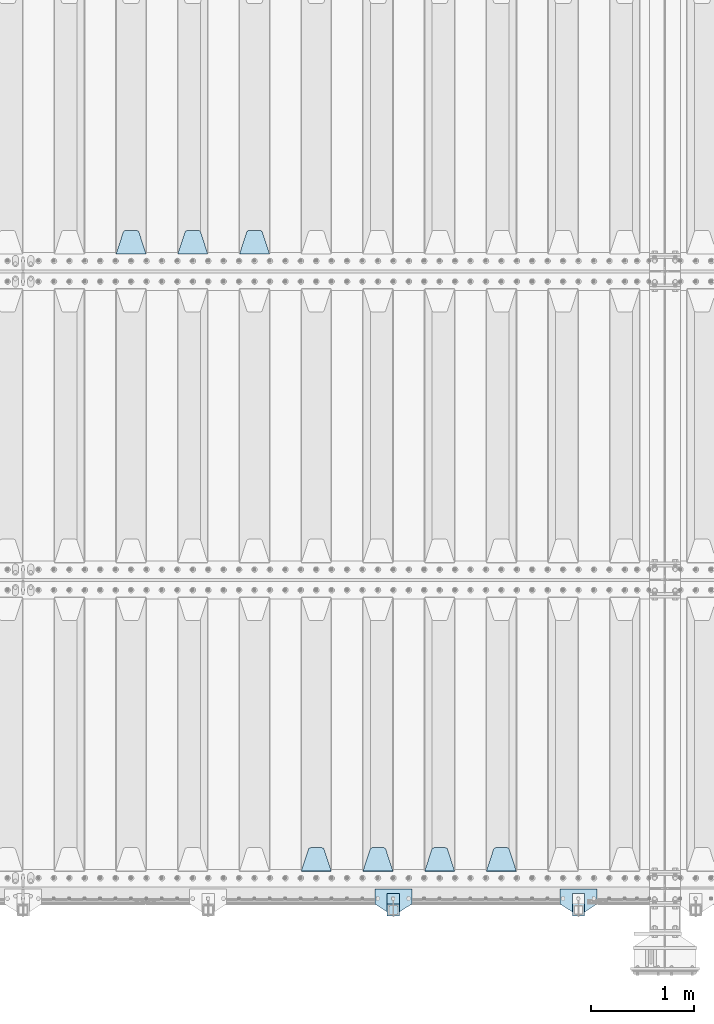
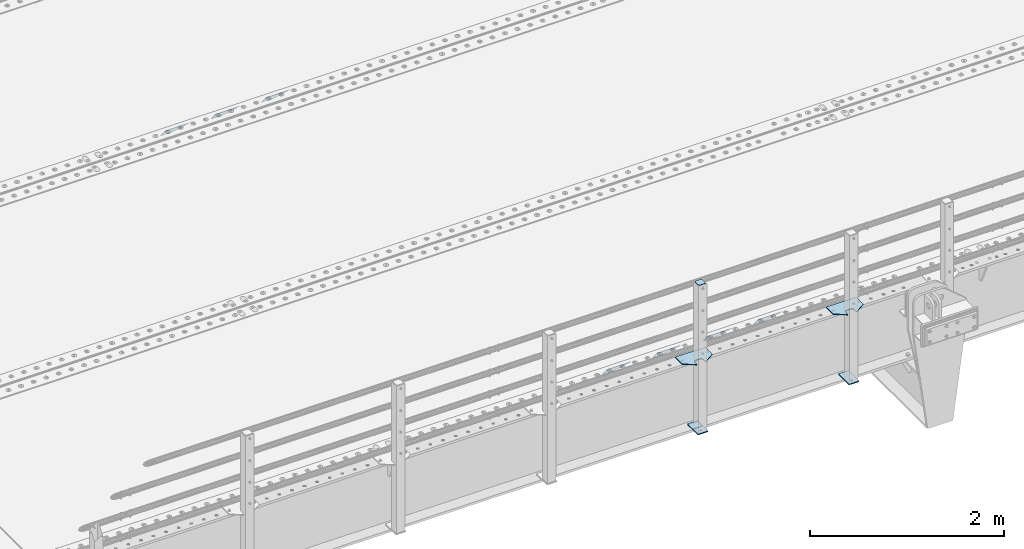
# One storey, part 197 of 240: 13 plates.
"""IFC2X3 building model written with IfcOpenShell, lengths in millimetres."""

from ifc_helpers import new_model, si_unit, frame, origin_with_axes, place, context, subcontext, project, spatial, faceted_brep, material, type_object, element, save


model = new_model("IFC2X3")

# Units and contexts
model_context = context("Model", 3, precision=1e-05, world=origin_with_axes())
body_context = subcontext(model_context, "Body", "Model", "MODEL_VIEW")
ifc_project = project(units=[si_unit("LENGTHUNIT", "METRE", prefix="MILLI"), si_unit("AREAUNIT", "SQUARE_METRE"), si_unit("VOLUMEUNIT", "CUBIC_METRE"), si_unit("MASSUNIT", "GRAM", prefix="KILO"), si_unit("TIMEUNIT", "SECOND"), si_unit("PLANEANGLEUNIT", "RADIAN"), si_unit("SOLIDANGLEUNIT", "STERADIAN"), si_unit("THERMODYNAMICTEMPERATUREUNIT", "DEGREE_CELSIUS"), si_unit("LUMINOUSINTENSITYUNIT", "LUMEN")], contexts=[model_context])

# Site, building, storey
site_placement = place(None, origin_with_axes())
site = spatial("IfcSite", under=ifc_project, at=site_placement, CompositionType="ELEMENT")
building_placement = place(site_placement, origin_with_axes())
building = spatial("IfcBuilding", under=site, at=building_placement, Name="Standard", CompositionType="ELEMENT")
storey_placement = place(building_placement, origin_with_axes())
storey = spatial("IfcBuildingStorey", under=building, at=storey_placement, Name="Undefined", CompositionType="ELEMENT", Elevation=0.0)

# Plates
ifc_material_1 = material(Name="STEEL/S355N")
plate_type_1 = type_object("IfcPlateType", PredefinedType="NOTDEFINED")
plate_1_placement = place(storey_placement, frame((48995.0, 30168.232233047, -1.76776695296758), z_axis=(0.0, 0.707106781186547, -0.707106781186548), x_axis=(-1.0, 0.0, 0.0)))
element("IfcPlate", 1, at=plate_1_placement, inside=storey, type_object=plate_type_1, material=ifc_material_1, context=body_context, shape_type="Brep", body=[
    faceted_brep([(0.0, -2.5, 0.0), (69.345504679477, -2.50000000000364, 300.171731424827), (69.345504679477, 2.49999999999636, 300.171731424827), (0.0, 2.5, 0.0), (70.927406119954, -2.50000000000364, 304.897442415397), (70.927406119954, 2.49999999999636, 304.897442415397), (73.3818627772271, -2.50000000000728, 309.234538108525), (73.3818627772271, 2.49999999999636, 309.234538108529), (76.6187032999587, -2.50000000000728, 313.023683126099), (76.6187032999587, 2.49999999999636, 313.023683126103), (80.5190132705029, -2.50000000000364, 316.125672595368), (80.5190132705029, 2.49999999999636, 316.125672595368), (84.9395038596849, -2.50000000000364, 318.426546230472), (84.9395038596849, 2.49999999999636, 318.426546230472), (89.7177759439219, -2.5, 319.841774983277), (89.7177759439219, 2.49999999999636, 319.841774983273), (94.6782862926484, -2.50000000000364, 320.319366455074), (94.6782862926484, 2.49999999999636, 320.319366455074), (195.321713707352, -2.50000000000364, 320.319366455074), (195.321713707352, 2.49999999999636, 320.319366455074), (200.282224056078, -2.50000000000364, 319.841774983273), (200.282224056078, 2.49999999999636, 319.841774983273), (205.060496140315, -2.50000000000364, 318.426546230472), (205.060496140315, 2.49999999999636, 318.426546230472), (209.480986729497, -2.50000000000364, 316.125672595368), (209.480986729497, 2.49999999999636, 316.125672595368), (213.381296700041, -2.50000000000728, 313.023683126099), (213.381296700041, 2.49999999999272, 313.023683126099), (216.618137222766, -2.50000000000364, 309.234538108522), (216.618137222766, 2.49999999999636, 309.234538108522), (219.072593880039, -2.50000000000364, 304.897442415397), (219.072593880039, 2.49999999999636, 304.897442415397), (220.654495320523, -2.50000000000364, 300.171731424827), (220.654495320523, 2.49999999999636, 300.171731424827), (290.0, -2.50000000000364, -3.63797880709171e-12), (290.0, 2.49999999999636, -3.63797880709171e-12)], [[[0, 1, 2, 3]], [[1, 4, 5, 2]], [[4, 6, 7, 5]], [[6, 8, 9, 7]], [[8, 10, 11, 9]], [[10, 12, 13, 11]], [[12, 14, 15, 13]], [[14, 16, 17, 15]], [[16, 18, 19, 17]], [[18, 20, 21, 19]], [[20, 22, 23, 21]], [[22, 24, 25, 23]], [[24, 26, 27, 25]], [[26, 28, 29, 27]], [[28, 30, 31, 29]], [[30, 32, 33, 31]], [[32, 34, 35, 33]], [[34, 0, 3, 35]], [[5, 7, 9, 11, 13, 15, 17, 19, 21, 23, 25, 27, 29, 31, 33, 35, 3, 2]], [[34, 32, 30, 28, 26, 24, 22, 20, 18, 16, 14, 12, 10, 8, 6, 4, 1, 0]]]),
])
plate_2_placement = place(storey_placement, frame((48395.0, 30168.232233047, -1.76776695296758), z_axis=(0.0, 0.707106781186547, -0.707106781186548), x_axis=(-1.0, 0.0, 0.0)))
element("IfcPlate", 2, at=plate_2_placement, inside=storey, type_object=plate_type_1, material=ifc_material_1, context=body_context, shape_type="Brep", body=[
    faceted_brep([(0.0, -2.5, 0.0), (69.345504679477, -2.50000000000364, 300.171731424827), (69.345504679477, 2.49999999999636, 300.171731424827), (0.0, 2.5, 0.0), (70.927406119954, -2.50000000000364, 304.897442415397), (70.927406119954, 2.49999999999636, 304.897442415397), (73.3818627772271, -2.50000000000728, 309.234538108525), (73.3818627772271, 2.49999999999636, 309.234538108529), (76.6187032999587, -2.50000000000728, 313.023683126099), (76.6187032999587, 2.49999999999636, 313.023683126103), (80.5190132705029, -2.50000000000364, 316.125672595368), (80.5190132705029, 2.49999999999636, 316.125672595368), (84.9395038596849, -2.50000000000364, 318.426546230472), (84.9395038596849, 2.49999999999636, 318.426546230472), (89.7177759439219, -2.5, 319.841774983277), (89.7177759439219, 2.49999999999636, 319.841774983273), (94.6782862926484, -2.50000000000364, 320.319366455074), (94.6782862926484, 2.49999999999636, 320.319366455074), (195.321713707352, -2.50000000000364, 320.319366455074), (195.321713707352, 2.49999999999636, 320.319366455074), (200.282224056078, -2.50000000000364, 319.841774983273), (200.282224056078, 2.49999999999636, 319.841774983273), (205.060496140315, -2.50000000000364, 318.426546230472), (205.060496140315, 2.49999999999636, 318.426546230472), (209.480986729497, -2.50000000000364, 316.125672595368), (209.480986729497, 2.49999999999636, 316.125672595368), (213.381296700041, -2.50000000000728, 313.023683126099), (213.381296700041, 2.49999999999272, 313.023683126099), (216.618137222766, -2.50000000000364, 309.234538108522), (216.618137222766, 2.49999999999636, 309.234538108522), (219.072593880039, -2.50000000000364, 304.897442415397), (219.072593880039, 2.49999999999636, 304.897442415397), (220.654495320523, -2.50000000000364, 300.171731424827), (220.654495320523, 2.49999999999636, 300.171731424827), (290.0, -2.50000000000364, -3.63797880709171e-12), (290.0, 2.49999999999636, -3.63797880709171e-12)], [[[0, 1, 2, 3]], [[1, 4, 5, 2]], [[4, 6, 7, 5]], [[6, 8, 9, 7]], [[8, 10, 11, 9]], [[10, 12, 13, 11]], [[12, 14, 15, 13]], [[14, 16, 17, 15]], [[16, 18, 19, 17]], [[18, 20, 21, 19]], [[20, 22, 23, 21]], [[22, 24, 25, 23]], [[24, 26, 27, 25]], [[26, 28, 29, 27]], [[28, 30, 31, 29]], [[30, 32, 33, 31]], [[32, 34, 35, 33]], [[34, 0, 3, 35]], [[5, 7, 9, 11, 13, 15, 17, 19, 21, 23, 25, 27, 29, 31, 33, 35, 3, 2]], [[34, 32, 30, 28, 26, 24, 22, 20, 18, 16, 14, 12, 10, 8, 6, 4, 1, 0]]]),
])
plate_3_placement = place(storey_placement, frame((47795.0, 30168.232233047, -1.76776695296758), z_axis=(0.0, 0.707106781186547, -0.707106781186548), x_axis=(-1.0, 0.0, 0.0)))
element("IfcPlate", 3, at=plate_3_placement, inside=storey, type_object=plate_type_1, material=ifc_material_1, context=body_context, shape_type="Brep", body=[
    faceted_brep([(0.0, -2.5, 0.0), (69.345504679477, -2.50000000000364, 300.171731424827), (69.345504679477, 2.49999999999636, 300.171731424827), (0.0, 2.5, 0.0), (70.927406119954, -2.50000000000364, 304.897442415397), (70.927406119954, 2.49999999999636, 304.897442415397), (73.3818627772271, -2.50000000000728, 309.234538108525), (73.3818627772271, 2.49999999999636, 309.234538108529), (76.6187032999587, -2.50000000000728, 313.023683126099), (76.6187032999587, 2.49999999999636, 313.023683126103), (80.5190132705029, -2.50000000000364, 316.125672595368), (80.5190132705029, 2.49999999999636, 316.125672595368), (84.9395038596849, -2.50000000000364, 318.426546230472), (84.9395038596849, 2.49999999999636, 318.426546230472), (89.7177759439219, -2.5, 319.841774983277), (89.7177759439219, 2.49999999999636, 319.841774983273), (94.6782862926484, -2.50000000000364, 320.319366455074), (94.6782862926484, 2.49999999999636, 320.319366455074), (195.321713707352, -2.50000000000364, 320.319366455074), (195.321713707352, 2.49999999999636, 320.319366455074), (200.282224056078, -2.50000000000364, 319.841774983273), (200.282224056078, 2.49999999999636, 319.841774983273), (205.060496140315, -2.50000000000364, 318.426546230472), (205.060496140315, 2.49999999999636, 318.426546230472), (209.480986729497, -2.50000000000364, 316.125672595368), (209.480986729497, 2.49999999999636, 316.125672595368), (213.381296700041, -2.50000000000728, 313.023683126099), (213.381296700041, 2.49999999999272, 313.023683126099), (216.618137222766, -2.50000000000364, 309.234538108522), (216.618137222766, 2.49999999999636, 309.234538108522), (219.072593880039, -2.50000000000364, 304.897442415397), (219.072593880039, 2.49999999999636, 304.897442415397), (220.654495320523, -2.50000000000364, 300.171731424827), (220.654495320523, 2.49999999999636, 300.171731424827), (290.0, -2.50000000000364, -3.63797880709171e-12), (290.0, 2.49999999999636, -3.63797880709171e-12)], [[[0, 1, 2, 3]], [[1, 4, 5, 2]], [[4, 6, 7, 5]], [[6, 8, 9, 7]], [[8, 10, 11, 9]], [[10, 12, 13, 11]], [[12, 14, 15, 13]], [[14, 16, 17, 15]], [[16, 18, 19, 17]], [[18, 20, 21, 19]], [[20, 22, 23, 21]], [[22, 24, 25, 23]], [[24, 26, 27, 25]], [[26, 28, 29, 27]], [[28, 30, 31, 29]], [[30, 32, 33, 31]], [[32, 34, 35, 33]], [[34, 0, 3, 35]], [[5, 7, 9, 11, 13, 15, 17, 19, 21, 23, 25, 27, 29, 31, 33, 35, 3, 2]], [[34, 32, 30, 28, 26, 24, 22, 20, 18, 16, 14, 12, 10, 8, 6, 4, 1, 0]]]),
])
plate_4_placement = place(storey_placement, frame((51395.0, 24168.232233047, -1.76776695296758), z_axis=(0.0, 0.707106781186547, -0.707106781186548), x_axis=(-1.0, 0.0, 0.0)))
element("IfcPlate", 4, at=plate_4_placement, inside=storey, type_object=plate_type_1, material=ifc_material_1, context=body_context, shape_type="Brep", body=[
    faceted_brep([(0.0, -2.5, 0.0), (69.345504679477, -2.50000000000364, 300.171731424827), (69.345504679477, 2.49999999999636, 300.171731424827), (0.0, 2.5, 0.0), (70.927406119954, -2.50000000000364, 304.897442415397), (70.927406119954, 2.49999999999636, 304.897442415397), (73.3818627772271, -2.50000000000728, 309.234538108525), (73.3818627772271, 2.49999999999636, 309.234538108529), (76.6187032999587, -2.50000000000728, 313.023683126099), (76.6187032999587, 2.49999999999636, 313.023683126103), (80.5190132705029, -2.50000000000364, 316.125672595368), (80.5190132705029, 2.49999999999636, 316.125672595368), (84.9395038596849, -2.50000000000364, 318.426546230472), (84.9395038596849, 2.49999999999636, 318.426546230472), (89.7177759439219, -2.5, 319.841774983277), (89.7177759439219, 2.49999999999636, 319.841774983273), (94.6782862926484, -2.50000000000364, 320.319366455074), (94.6782862926484, 2.49999999999636, 320.319366455074), (195.321713707352, -2.50000000000364, 320.319366455074), (195.321713707352, 2.49999999999636, 320.319366455074), (200.282224056078, -2.50000000000364, 319.841774983273), (200.282224056078, 2.49999999999636, 319.841774983273), (205.060496140315, -2.50000000000364, 318.426546230472), (205.060496140315, 2.49999999999636, 318.426546230472), (209.480986729497, -2.50000000000364, 316.125672595368), (209.480986729497, 2.49999999999636, 316.125672595368), (213.381296700041, -2.50000000000728, 313.023683126099), (213.381296700041, 2.49999999999272, 313.023683126099), (216.618137222766, -2.50000000000364, 309.234538108522), (216.618137222766, 2.49999999999636, 309.234538108522), (219.072593880039, -2.50000000000364, 304.897442415397), (219.072593880039, 2.49999999999636, 304.897442415397), (220.654495320523, -2.50000000000364, 300.171731424827), (220.654495320523, 2.49999999999636, 300.171731424827), (290.0, -2.50000000000364, -3.63797880709171e-12), (290.0, 2.49999999999636, -3.63797880709171e-12)], [[[0, 1, 2, 3]], [[1, 4, 5, 2]], [[4, 6, 7, 5]], [[6, 8, 9, 7]], [[8, 10, 11, 9]], [[10, 12, 13, 11]], [[12, 14, 15, 13]], [[14, 16, 17, 15]], [[16, 18, 19, 17]], [[18, 20, 21, 19]], [[20, 22, 23, 21]], [[22, 24, 25, 23]], [[24, 26, 27, 25]], [[26, 28, 29, 27]], [[28, 30, 31, 29]], [[30, 32, 33, 31]], [[32, 34, 35, 33]], [[34, 0, 3, 35]], [[5, 7, 9, 11, 13, 15, 17, 19, 21, 23, 25, 27, 29, 31, 33, 35, 3, 2]], [[34, 32, 30, 28, 26, 24, 22, 20, 18, 16, 14, 12, 10, 8, 6, 4, 1, 0]]]),
])
plate_5_placement = place(storey_placement, frame((50795.0, 24168.232233047, -1.76776695296758), z_axis=(0.0, 0.707106781186547, -0.707106781186548), x_axis=(-1.0, 0.0, 0.0)))
element("IfcPlate", 5, at=plate_5_placement, inside=storey, type_object=plate_type_1, material=ifc_material_1, context=body_context, shape_type="Brep", body=[
    faceted_brep([(0.0, -2.5, 0.0), (69.345504679477, -2.50000000000364, 300.171731424827), (69.345504679477, 2.49999999999636, 300.171731424827), (0.0, 2.5, 0.0), (70.927406119954, -2.50000000000364, 304.897442415397), (70.927406119954, 2.49999999999636, 304.897442415397), (73.3818627772271, -2.50000000000728, 309.234538108525), (73.3818627772271, 2.49999999999636, 309.234538108529), (76.6187032999587, -2.50000000000728, 313.023683126099), (76.6187032999587, 2.49999999999636, 313.023683126103), (80.5190132705029, -2.50000000000364, 316.125672595368), (80.5190132705029, 2.49999999999636, 316.125672595368), (84.9395038596849, -2.50000000000364, 318.426546230472), (84.9395038596849, 2.49999999999636, 318.426546230472), (89.7177759439219, -2.5, 319.841774983277), (89.7177759439219, 2.49999999999636, 319.841774983273), (94.6782862926484, -2.50000000000364, 320.319366455074), (94.6782862926484, 2.49999999999636, 320.319366455074), (195.321713707352, -2.50000000000364, 320.319366455074), (195.321713707352, 2.49999999999636, 320.319366455074), (200.282224056078, -2.50000000000364, 319.841774983273), (200.282224056078, 2.49999999999636, 319.841774983273), (205.060496140315, -2.50000000000364, 318.426546230472), (205.060496140315, 2.49999999999636, 318.426546230472), (209.480986729497, -2.50000000000364, 316.125672595368), (209.480986729497, 2.49999999999636, 316.125672595368), (213.381296700041, -2.50000000000728, 313.023683126099), (213.381296700041, 2.49999999999272, 313.023683126099), (216.618137222766, -2.50000000000364, 309.234538108522), (216.618137222766, 2.49999999999636, 309.234538108522), (219.072593880039, -2.50000000000364, 304.897442415397), (219.072593880039, 2.49999999999636, 304.897442415397), (220.654495320523, -2.50000000000364, 300.171731424827), (220.654495320523, 2.49999999999636, 300.171731424827), (290.0, -2.50000000000364, -3.63797880709171e-12), (290.0, 2.49999999999636, -3.63797880709171e-12)], [[[0, 1, 2, 3]], [[1, 4, 5, 2]], [[4, 6, 7, 5]], [[6, 8, 9, 7]], [[8, 10, 11, 9]], [[10, 12, 13, 11]], [[12, 14, 15, 13]], [[14, 16, 17, 15]], [[16, 18, 19, 17]], [[18, 20, 21, 19]], [[20, 22, 23, 21]], [[22, 24, 25, 23]], [[24, 26, 27, 25]], [[26, 28, 29, 27]], [[28, 30, 31, 29]], [[30, 32, 33, 31]], [[32, 34, 35, 33]], [[34, 0, 3, 35]], [[5, 7, 9, 11, 13, 15, 17, 19, 21, 23, 25, 27, 29, 31, 33, 35, 3, 2]], [[34, 32, 30, 28, 26, 24, 22, 20, 18, 16, 14, 12, 10, 8, 6, 4, 1, 0]]]),
])
plate_6_placement = place(storey_placement, frame((50195.0, 24168.232233047, -1.76776695296758), z_axis=(0.0, 0.707106781186547, -0.707106781186548), x_axis=(-1.0, 0.0, 0.0)))
element("IfcPlate", 6, at=plate_6_placement, inside=storey, type_object=plate_type_1, material=ifc_material_1, context=body_context, shape_type="Brep", body=[
    faceted_brep([(0.0, -2.5, 0.0), (69.345504679477, -2.50000000000364, 300.171731424827), (69.345504679477, 2.49999999999636, 300.171731424827), (0.0, 2.5, 0.0), (70.927406119954, -2.50000000000364, 304.897442415397), (70.927406119954, 2.49999999999636, 304.897442415397), (73.3818627772271, -2.50000000000728, 309.234538108525), (73.3818627772271, 2.49999999999636, 309.234538108529), (76.6187032999587, -2.50000000000728, 313.023683126099), (76.6187032999587, 2.49999999999636, 313.023683126103), (80.5190132705029, -2.50000000000364, 316.125672595368), (80.5190132705029, 2.49999999999636, 316.125672595368), (84.9395038596849, -2.50000000000364, 318.426546230472), (84.9395038596849, 2.49999999999636, 318.426546230472), (89.7177759439219, -2.5, 319.841774983277), (89.7177759439219, 2.49999999999636, 319.841774983273), (94.6782862926484, -2.50000000000364, 320.319366455074), (94.6782862926484, 2.49999999999636, 320.319366455074), (195.321713707352, -2.50000000000364, 320.319366455074), (195.321713707352, 2.49999999999636, 320.319366455074), (200.282224056078, -2.50000000000364, 319.841774983273), (200.282224056078, 2.49999999999636, 319.841774983273), (205.060496140315, -2.50000000000364, 318.426546230472), (205.060496140315, 2.49999999999636, 318.426546230472), (209.480986729497, -2.50000000000364, 316.125672595368), (209.480986729497, 2.49999999999636, 316.125672595368), (213.381296700041, -2.50000000000728, 313.023683126099), (213.381296700041, 2.49999999999272, 313.023683126099), (216.618137222766, -2.50000000000364, 309.234538108522), (216.618137222766, 2.49999999999636, 309.234538108522), (219.072593880039, -2.50000000000364, 304.897442415397), (219.072593880039, 2.49999999999636, 304.897442415397), (220.654495320523, -2.50000000000364, 300.171731424827), (220.654495320523, 2.49999999999636, 300.171731424827), (290.0, -2.50000000000364, -3.63797880709171e-12), (290.0, 2.49999999999636, -3.63797880709171e-12)], [[[0, 1, 2, 3]], [[1, 4, 5, 2]], [[4, 6, 7, 5]], [[6, 8, 9, 7]], [[8, 10, 11, 9]], [[10, 12, 13, 11]], [[12, 14, 15, 13]], [[14, 16, 17, 15]], [[16, 18, 19, 17]], [[18, 20, 21, 19]], [[20, 22, 23, 21]], [[22, 24, 25, 23]], [[24, 26, 27, 25]], [[26, 28, 29, 27]], [[28, 30, 31, 29]], [[30, 32, 33, 31]], [[32, 34, 35, 33]], [[34, 0, 3, 35]], [[5, 7, 9, 11, 13, 15, 17, 19, 21, 23, 25, 27, 29, 31, 33, 35, 3, 2]], [[34, 32, 30, 28, 26, 24, 22, 20, 18, 16, 14, 12, 10, 8, 6, 4, 1, 0]]]),
])
plate_7_placement = place(storey_placement, frame((49595.0, 24168.232233047, -1.76776695296758), z_axis=(0.0, 0.707106781186547, -0.707106781186548), x_axis=(-1.0, 0.0, 0.0)))
element("IfcPlate", 7, at=plate_7_placement, inside=storey, type_object=plate_type_1, material=ifc_material_1, context=body_context, shape_type="Brep", body=[
    faceted_brep([(0.0, -2.5, 0.0), (69.345504679477, -2.50000000000364, 300.171731424827), (69.345504679477, 2.49999999999636, 300.171731424827), (0.0, 2.5, 0.0), (70.927406119954, -2.50000000000364, 304.897442415397), (70.927406119954, 2.49999999999636, 304.897442415397), (73.3818627772271, -2.50000000000728, 309.234538108525), (73.3818627772271, 2.49999999999636, 309.234538108529), (76.6187032999587, -2.50000000000728, 313.023683126099), (76.6187032999587, 2.49999999999636, 313.023683126103), (80.5190132705029, -2.50000000000364, 316.125672595368), (80.5190132705029, 2.49999999999636, 316.125672595368), (84.9395038596849, -2.50000000000364, 318.426546230472), (84.9395038596849, 2.49999999999636, 318.426546230472), (89.7177759439219, -2.5, 319.841774983277), (89.7177759439219, 2.49999999999636, 319.841774983273), (94.6782862926484, -2.50000000000364, 320.319366455074), (94.6782862926484, 2.49999999999636, 320.319366455074), (195.321713707352, -2.50000000000364, 320.319366455074), (195.321713707352, 2.49999999999636, 320.319366455074), (200.282224056078, -2.50000000000364, 319.841774983273), (200.282224056078, 2.49999999999636, 319.841774983273), (205.060496140315, -2.50000000000364, 318.426546230472), (205.060496140315, 2.49999999999636, 318.426546230472), (209.480986729497, -2.50000000000364, 316.125672595368), (209.480986729497, 2.49999999999636, 316.125672595368), (213.381296700041, -2.50000000000728, 313.023683126099), (213.381296700041, 2.49999999999272, 313.023683126099), (216.618137222766, -2.50000000000364, 309.234538108522), (216.618137222766, 2.49999999999636, 309.234538108522), (219.072593880039, -2.50000000000364, 304.897442415397), (219.072593880039, 2.49999999999636, 304.897442415397), (220.654495320523, -2.50000000000364, 300.171731424827), (220.654495320523, 2.49999999999636, 300.171731424827), (290.0, -2.50000000000364, -3.63797880709171e-12), (290.0, 2.49999999999636, -3.63797880709171e-12)], [[[0, 1, 2, 3]], [[1, 4, 5, 2]], [[4, 6, 7, 5]], [[6, 8, 9, 7]], [[8, 10, 11, 9]], [[10, 12, 13, 11]], [[12, 14, 15, 13]], [[14, 16, 17, 15]], [[16, 18, 19, 17]], [[18, 20, 21, 19]], [[20, 22, 23, 21]], [[22, 24, 25, 23]], [[24, 26, 27, 25]], [[26, 28, 29, 27]], [[28, 30, 31, 29]], [[30, 32, 33, 31]], [[32, 34, 35, 33]], [[34, 0, 3, 35]], [[5, 7, 9, 11, 13, 15, 17, 19, 21, 23, 25, 27, 29, 31, 33, 35, 3, 2]], [[34, 32, 30, 28, 26, 24, 22, 20, 18, 16, 14, 12, 10, 8, 6, 4, 1, 0]]]),
])
ifc_material_2 = material(Name="STEEL/S355J2")
plate_type_2 = type_object("IfcPlateType", PredefinedType="NOTDEFINED")
plate_8_placement = place(storey_placement, frame((52180.0, 23995.0, 5.00000000004911), z_axis=(0.0, -1.0, 0.0), x_axis=(-1.0, 0.0, 0.0)))
element("IfcPlate", 8, at=plate_8_placement, inside=storey, type_object=plate_type_2, material=ifc_material_2, context=body_context, shape_type="Brep", body=[
    faceted_brep([(0.0, -5.0, 0.0), (2.31396552408114e-06, -5.0, 145.0), (2.31396552408114e-06, 5.0, 145.0), (0.0, 5.0, 0.0), (130.0, -5.0, 230.0), (130.0, 5.0, 230.0), (130.0, -5.0, 180.0), (130.0, 5.0, 180.0), (130.48036798992, -5.0, 175.122741949599), (130.48036798992, 5.0, 175.122741949599), (131.903011687216, -5.0, 170.432914190875), (131.903011687216, 5.0, 170.432914190875), (134.213259692435, -5.0, 166.110744174512), (134.213259692435, 5.0, 166.110744174512), (137.322330470335, -5.0, 162.322330470335), (137.322330470335, 5.0, 162.322330470335), (141.110744174512, -5.0, 159.213259692435), (141.110744174512, 5.0, 159.213259692435), (145.432914190875, -5.0, 156.903011687216), (145.432914190875, 5.0, 156.903011687216), (150.122741949599, -5.0, 155.48036798992), (150.122741949599, 5.0, 155.48036798992), (155.0, -5.0, 155.0), (155.0, 5.0, 155.0), (205.0, -5.0, 155.0), (205.0, 5.0, 155.0), (209.877258050401, -5.0, 155.48036798992), (209.877258050401, 5.0, 155.48036798992), (214.567085809125, -5.0, 156.903011687216), (214.567085809125, 5.0, 156.903011687216), (218.889255825488, -5.0, 159.213259692435), (218.889255825488, 5.0, 159.213259692435), (222.677669529665, -5.0, 162.322330470335), (222.677669529665, 5.0, 162.322330470335), (225.786740307565, -5.0, 166.110744174512), (225.786740307565, 5.0, 166.110744174512), (228.096988312784, -5.0, 170.432914190875), (228.096988312784, 5.0, 170.432914190875), (229.51963201008, -5.0, 175.122741949599), (229.51963201008, 5.0, 175.122741949599), (230.0, -5.0, 180.0), (230.0, 5.0, 180.0), (230.0, -5.0, 230.0), (230.0, 5.0, 230.0), (360.0, -5.0, 145.0), (360.0, 5.0, 145.0), (360.0, -5.0, -7.27595761418343e-12), (360.0, 5.0, -7.27595761418343e-12)], [[[0, 1, 2, 3]], [[1, 4, 5, 2]], [[4, 6, 7, 5]], [[6, 8, 9, 7]], [[8, 10, 11, 9]], [[10, 12, 13, 11]], [[12, 14, 15, 13]], [[14, 16, 17, 15]], [[16, 18, 19, 17]], [[18, 20, 21, 19]], [[20, 22, 23, 21]], [[22, 24, 25, 23]], [[24, 26, 27, 25]], [[26, 28, 29, 27]], [[28, 30, 31, 29]], [[30, 32, 33, 31]], [[32, 34, 35, 33]], [[34, 36, 37, 35]], [[36, 38, 39, 37]], [[38, 40, 41, 39]], [[40, 42, 43, 41]], [[42, 44, 45, 43]], [[44, 46, 47, 45]], [[46, 0, 3, 47]], [[5, 7, 9, 11, 13, 15, 17, 19, 21, 23, 25, 27, 29, 31, 33, 35, 37, 39, 41, 43, 45, 47, 3, 2]], [[46, 44, 42, 40, 38, 36, 34, 32, 30, 28, 26, 24, 22, 20, 18, 16, 14, 12, 10, 8, 6, 4, 1, 0]]]),
])
plate_9_placement = place(storey_placement, frame((50380.0, 23995.0, 5.00000000004911), z_axis=(0.0, -1.0, 0.0), x_axis=(-1.0, 0.0, 0.0)))
element("IfcPlate", 9, at=plate_9_placement, inside=storey, type_object=plate_type_2, material=ifc_material_2, context=body_context, shape_type="Brep", body=[
    faceted_brep([(0.0, -5.0, 0.0), (2.31396552408114e-06, -5.0, 145.0), (2.31396552408114e-06, 5.0, 145.0), (0.0, 5.0, 0.0), (130.0, -5.0, 230.0), (130.0, 5.0, 230.0), (130.0, -5.0, 180.0), (130.0, 5.0, 180.0), (130.48036798992, -5.0, 175.122741949599), (130.48036798992, 5.0, 175.122741949599), (131.903011687216, -5.0, 170.432914190875), (131.903011687216, 5.0, 170.432914190875), (134.213259692435, -5.0, 166.110744174512), (134.213259692435, 5.0, 166.110744174512), (137.322330470335, -5.0, 162.322330470335), (137.322330470335, 5.0, 162.322330470335), (141.110744174512, -5.0, 159.213259692435), (141.110744174512, 5.0, 159.213259692435), (145.432914190875, -5.0, 156.903011687216), (145.432914190875, 5.0, 156.903011687216), (150.122741949599, -5.0, 155.48036798992), (150.122741949599, 5.0, 155.48036798992), (155.0, -5.0, 155.0), (155.0, 5.0, 155.0), (205.0, -5.0, 155.0), (205.0, 5.0, 155.0), (209.877258050401, -5.0, 155.48036798992), (209.877258050401, 5.0, 155.48036798992), (214.567085809125, -5.0, 156.903011687216), (214.567085809125, 5.0, 156.903011687216), (218.889255825488, -5.0, 159.213259692435), (218.889255825488, 5.0, 159.213259692435), (222.677669529665, -5.0, 162.322330470335), (222.677669529665, 5.0, 162.322330470335), (225.786740307565, -5.0, 166.110744174512), (225.786740307565, 5.0, 166.110744174512), (228.096988312784, -5.0, 170.432914190875), (228.096988312784, 5.0, 170.432914190875), (229.51963201008, -5.0, 175.122741949599), (229.51963201008, 5.0, 175.122741949599), (230.0, -5.0, 180.0), (230.0, 5.0, 180.0), (230.0, -5.0, 230.0), (230.0, 5.0, 230.0), (360.0, -5.0, 145.0), (360.0, 5.0, 145.0), (360.0, -5.0, -7.27595761418343e-12), (360.0, 5.0, -7.27595761418343e-12)], [[[0, 1, 2, 3]], [[1, 4, 5, 2]], [[4, 6, 7, 5]], [[6, 8, 9, 7]], [[8, 10, 11, 9]], [[10, 12, 13, 11]], [[12, 14, 15, 13]], [[14, 16, 17, 15]], [[16, 18, 19, 17]], [[18, 20, 21, 19]], [[20, 22, 23, 21]], [[22, 24, 25, 23]], [[24, 26, 27, 25]], [[26, 28, 29, 27]], [[28, 30, 31, 29]], [[30, 32, 33, 31]], [[32, 34, 35, 33]], [[34, 36, 37, 35]], [[36, 38, 39, 37]], [[38, 40, 41, 39]], [[40, 42, 43, 41]], [[42, 44, 45, 43]], [[44, 46, 47, 45]], [[46, 0, 3, 47]], [[5, 7, 9, 11, 13, 15, 17, 19, 21, 23, 25, 27, 29, 31, 33, 35, 37, 39, 41, 43, 45, 47, 3, 2]], [[46, 44, 42, 40, 38, 36, 34, 32, 30, 28, 26, 24, 22, 20, 18, 16, 14, 12, 10, 8, 6, 4, 1, 0]]]),
])
plate_type_3 = type_object("IfcPlateType", PredefinedType="NOTDEFINED")
for number, where, z_axis, x_axis in (
    (10, (52059.9999999999, 23949.9999999998, -850.000000000002), (0.0, -1.0, 0.0), (-1.0, 0.0, 0.0)),
    (11, (50259.9999999999, 23949.9999999998, -850.000000000002), (0.0, -1.0, 0.0), (-1.0, 0.0, 0.0)),
):
    element("IfcPlate", number, at=place(storey_placement, frame(where, z_axis=z_axis, x_axis=x_axis)), inside=storey, type_object=plate_type_3, material=ifc_material_2, context=body_context, shape_type="Brep", body=[
        faceted_brep([(53.6360389691836, -5.0, 176.363961030467), (53.6360389691836, 5.0, 176.363961030467), (59.9999999998618, 5.0, 178.999999999789), (59.9999999998618, -5.0, 178.999999999789), (66.3639610305399, 5.0, 176.363961030467), (66.3639610305399, -5.0, 176.363961030467), (68.9999999998618, 5.0, 169.999999999789), (68.9999999998618, -5.0, 169.999999999789), (66.3639610305399, 5.0, 163.636038969111), (66.3639610305399, -5.0, 163.636038969111), (59.9999999998618, 5.0, 160.999999999789), (59.9999999998618, -5.0, 160.999999999789), (53.6360389691836, 5.0, 163.636038969111), (53.6360389691836, -5.0, 163.636038969111), (50.9999999998618, 5.0, 169.999999999789), (50.9999999998618, -5.0, 169.999999999789), (120.0, -5.0, 0.0), (120.0, -5.0, 220.0), (0.0, -5.0, 220.0), (0.0, -5.0, 0.0), (0.0, 5.0, 0.0), (120.0, 5.0, 0.0), (120.0, 5.0, 220.0), (0.0, 5.0, 220.0)], [[[0, 1, 2, 3]], [[3, 2, 4, 5]], [[5, 4, 6, 7]], [[7, 6, 8, 9]], [[9, 8, 10, 11]], [[11, 10, 12, 13]], [[13, 12, 14, 15]], [[15, 14, 1, 0]], [[16, 17, 18, 19], [11, 13, 15, 0, 3, 5, 7, 9]], [[16, 19, 20, 21]], [[17, 16, 21, 22]], [[18, 17, 22, 23]], [[19, 18, 23, 20]], [[22, 21, 20, 23], [2, 1, 14, 12, 10, 8, 6, 4]]]),
    ])
plate_type_4 = type_object("IfcPlateType", PredefinedType="NOTDEFINED")
plate_10_placement = place(storey_placement, frame((50155.9999999999, 23833.9999999998, 1012.50000000001), z_axis=(0.0, -1.0, 0.0), x_axis=(1.0, 0.0, 0.0)))
element("IfcPlate", 12, at=plate_10_placement, inside=storey, type_object=plate_type_4, material=ifc_material_2, context=body_context, shape_type="Brep", body=[
    faceted_brep([(0.0, -2.5, 19.0), (0.0, -2.5, 69.0), (0.0, 2.5, 69.0), (0.0, 2.5, 19.0), (0.476369668547704, -2.5, 73.2278977451715), (0.476369668547704, 2.5, 73.2278977451715), (1.88159150985302, -2.5, 77.2437910432345), (1.88159150985302, 2.5, 77.2437910432345), (4.14520183311106, -2.5, 80.8463062353185), (4.14520183311106, 2.5, 80.8463062353185), (7.15369376468152, -2.5, 83.8547981668889), (7.15369376468152, 2.5, 83.8547981668889), (10.7562089567655, -2.5, 86.118408490147), (10.7562089567655, 2.5, 86.118408490147), (14.7721022548285, -2.5, 87.5236303314523), (14.7721022548285, 2.5, 87.5236303314523), (19.0, -2.5, 88.0), (19.0, 2.5, 88.0), (69.0, -2.5, 88.0), (69.0, 2.5, 88.0), (73.2278977451715, -2.5, 87.5236303314523), (73.2278977451715, 2.5, 87.5236303314523), (77.2437910432345, -2.5, 86.118408490147), (77.2437910432345, 2.5, 86.118408490147), (80.8463062353185, -2.5, 83.8547981668889), (80.8463062353185, 2.5, 83.8547981668889), (83.8547981668889, -2.5, 80.8463062353185), (83.8547981668889, 2.5, 80.8463062353185), (86.118408490147, -2.5, 77.2437910432345), (86.118408490147, 2.5, 77.2437910432345), (87.5236303314523, -2.5, 73.2278977451715), (87.5236303314523, 2.5, 73.2278977451715), (88.0, -2.5, 69.0), (88.0, 2.5, 69.0), (88.0, -2.5, 19.0), (88.0, 2.5, 19.0), (87.5236303314523, -2.5, 14.7721022548285), (87.5236303314523, 2.5, 14.7721022548285), (86.118408490147, -2.5, 10.7562089567655), (86.118408490147, 2.5, 10.7562089567655), (83.8547981668889, -2.5, 7.15369376468152), (83.8547981668889, 2.5, 7.15369376468152), (80.8463062353185, -2.5, 4.14520183311106), (80.8463062353185, 2.5, 4.14520183311106), (77.2437910432345, -2.5, 1.88159150985302), (77.2437910432345, 2.5, 1.88159150985302), (73.2278977451715, -2.5, 0.476369668547704), (73.2278977451715, 2.5, 0.476369668547704), (69.0, -2.5, 0.0), (69.0, 2.5, 0.0), (19.0, -2.5, 0.0), (19.0, 2.5, 0.0), (14.7721022548285, -2.5, 0.476369668547704), (14.7721022548285, 2.5, 0.476369668547704), (10.7562089567655, -2.5, 1.88159150985302), (10.7562089567655, 2.5, 1.88159150985302), (7.15369376468152, -2.5, 4.14520183311106), (7.15369376468152, 2.5, 4.14520183311106), (4.14520183311106, -2.5, 7.15369376468152), (4.14520183311106, 2.5, 7.15369376468152), (1.88159150985302, -2.5, 10.7562089567655), (1.88159150985302, 2.5, 10.7562089567655), (0.476369668547704, -2.5, 14.7721022548285), (0.476369668547704, 2.5, 14.7721022548285)], [[[0, 1, 2, 3]], [[1, 4, 5, 2]], [[4, 6, 7, 5]], [[6, 8, 9, 7]], [[8, 10, 11, 9]], [[10, 12, 13, 11]], [[12, 14, 15, 13]], [[14, 16, 17, 15]], [[16, 18, 19, 17]], [[18, 20, 21, 19]], [[20, 22, 23, 21]], [[22, 24, 25, 23]], [[24, 26, 27, 25]], [[26, 28, 29, 27]], [[28, 30, 31, 29]], [[30, 32, 33, 31]], [[32, 34, 35, 33]], [[34, 36, 37, 35]], [[36, 38, 39, 37]], [[38, 40, 41, 39]], [[40, 42, 43, 41]], [[42, 44, 45, 43]], [[44, 46, 47, 45]], [[46, 48, 49, 47]], [[48, 50, 51, 49]], [[50, 52, 53, 51]], [[52, 54, 55, 53]], [[54, 56, 57, 55]], [[56, 58, 59, 57]], [[58, 60, 61, 59]], [[60, 62, 63, 61]], [[62, 0, 3, 63]], [[5, 7, 9, 11, 13, 15, 17, 19, 21, 23, 25, 27, 29, 31, 33, 35, 37, 39, 41, 43, 45, 47, 49, 51, 53, 55, 57, 59, 61, 63, 3, 2]], [[62, 60, 58, 56, 54, 52, 50, 48, 46, 44, 42, 40, 38, 36, 34, 32, 30, 28, 26, 24, 22, 20, 18, 16, 14, 12, 10, 8, 6, 4, 1, 0]]]),
])
plate_type_5 = type_object("IfcPlateType", PredefinedType="NOTDEFINED")
plate_11_placement = place(storey_placement, frame((50259.9999999999, 23949.9999999998, -857.500000000002), z_axis=(0.0, -1.0, 0.0), x_axis=(-1.0, 0.0, 0.0)))
element("IfcPlate", 13, at=plate_11_placement, inside=storey, type_object=plate_type_5, material=ifc_material_2, context=body_context, shape_type="Brep", body=[
    faceted_brep([(0.0, -2.5, 0.0), (0.0, -2.5, 100.0), (0.0, 2.5, 100.0), (0.0, 2.5, 0.0), (120.0, -2.5, 100.0), (120.0, 2.5, 100.0), (120.0, -2.5, 0.0), (120.0, 2.5, 0.0)], [[[0, 1, 2, 3]], [[1, 4, 5, 2]], [[4, 6, 7, 5]], [[6, 0, 3, 7]], [[5, 7, 3, 2]], [[6, 4, 1, 0]]]),
])

save(model, "model.ifc")
